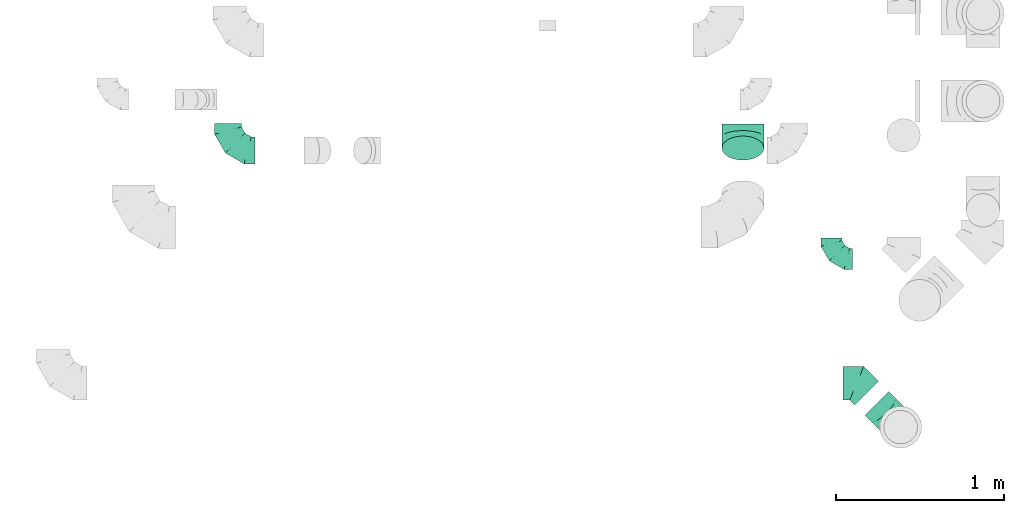
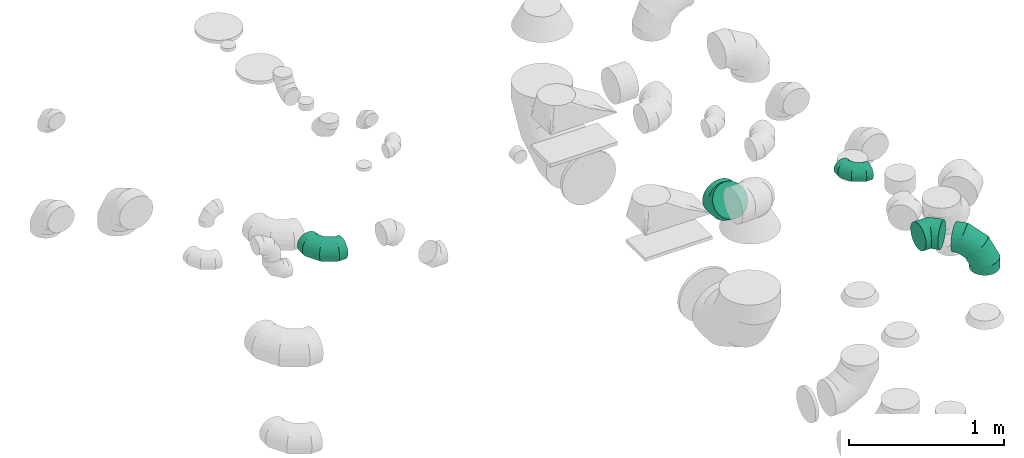
# One storey, part 41 of 59: 5 flow fittings.
"""IFC2X3 building model written with IfcOpenShell, lengths in millimetres."""

from ifc_helpers import new_model, entity, si_unit, converted_unit, derived_unit, direction, frame, origin, place, context, subcontext, project, spatial, faceted_brep, source, transform, mapped, material, type_object, type_shapes, element, save


model = new_model("IFC2X3")

# Units and contexts
model_context = context("Model", 3, precision=0.01, world=origin(), true_north=direction((6.12303176911189e-17, 1.0)))
body_context = subcontext(model_context, "Body", "Model", "MODEL_VIEW")
ifc_project = project(units=[si_unit("LENGTHUNIT", "METRE", prefix="MILLI"), si_unit("AREAUNIT", "SQUARE_METRE"), si_unit("VOLUMEUNIT", "CUBIC_METRE"), converted_unit("PLANEANGLEUNIT", "DEGREE", entity("IfcRatioMeasure", 0.0174532925199433), si_unit("PLANEANGLEUNIT", "RADIAN"), dimensions=[0, 0, 0, 0, 0, 0, 0]), si_unit("MASSUNIT", "GRAM", prefix="KILO"), derived_unit("MASSDENSITYUNIT", [(si_unit("MASSUNIT", "GRAM", prefix="KILO"), 1), (si_unit("LENGTHUNIT", "METRE"), -3)]), derived_unit("MOMENTOFINERTIAUNIT", [(si_unit("LENGTHUNIT", "METRE"), 4)]), si_unit("TIMEUNIT", "SECOND"), si_unit("FREQUENCYUNIT", "HERTZ"), si_unit("THERMODYNAMICTEMPERATUREUNIT", "DEGREE_CELSIUS"), derived_unit("THERMALTRANSMITTANCEUNIT", [(si_unit("MASSUNIT", "GRAM", prefix="KILO"), 1), (si_unit("THERMODYNAMICTEMPERATUREUNIT", "KELVIN"), -1), (si_unit("TIMEUNIT", "SECOND"), -3)]), derived_unit("VOLUMETRICFLOWRATEUNIT", [(si_unit("LENGTHUNIT", "METRE"), 3), (si_unit("TIMEUNIT", "SECOND"), -1)]), derived_unit("MASSFLOWRATEUNIT", [(si_unit("MASSUNIT", "GRAM", prefix="KILO"), 1), (si_unit("TIMEUNIT", "SECOND"), -1)]), derived_unit("ROTATIONALFREQUENCYUNIT", [(si_unit("TIMEUNIT", "SECOND"), -1)]), si_unit("ELECTRICCURRENTUNIT", "AMPERE"), si_unit("ELECTRICVOLTAGEUNIT", "VOLT"), si_unit("POWERUNIT", "WATT"), si_unit("FORCEUNIT", "NEWTON", prefix="KILO"), si_unit("ILLUMINANCEUNIT", "LUX"), si_unit("LUMINOUSFLUXUNIT", "LUMEN"), si_unit("LUMINOUSINTENSITYUNIT", "CANDELA"), derived_unit("USERDEFINED", [(si_unit("MASSUNIT", "GRAM", prefix="KILO"), -1), (si_unit("LENGTHUNIT", "METRE"), -2), (si_unit("TIMEUNIT", "SECOND"), 3), (si_unit("LUMINOUSFLUXUNIT", "LUMEN"), 1)]), derived_unit("LINEARVELOCITYUNIT", [(si_unit("LENGTHUNIT", "METRE"), 1), (si_unit("TIMEUNIT", "SECOND"), -1)]), si_unit("PRESSUREUNIT", "PASCAL"), derived_unit("USERDEFINED", [(si_unit("LENGTHUNIT", "METRE"), -2), (si_unit("MASSUNIT", "GRAM", prefix="KILO"), 1), (si_unit("TIMEUNIT", "SECOND"), -2)]), derived_unit("LINEARFORCEUNIT", [(si_unit("MASSUNIT", "GRAM", prefix="KILO"), 1), (si_unit("LENGTHUNIT", "METRE"), 1), (si_unit("TIMEUNIT", "SECOND"), -2), (si_unit("LENGTHUNIT", "METRE"), -1)]), derived_unit("PLANARFORCEUNIT", [(si_unit("MASSUNIT", "GRAM", prefix="KILO"), 1), (si_unit("LENGTHUNIT", "METRE"), 1), (si_unit("TIMEUNIT", "SECOND"), -2), (si_unit("LENGTHUNIT", "METRE"), -2)])], contexts=[model_context])

# Site, building, storey
site_placement = place(None, origin())
site = spatial("IfcSite", under=ifc_project, at=site_placement, CompositionType="ELEMENT")
building_placement = place(site_placement, origin())
building = spatial("IfcBuilding", under=site, at=building_placement, CompositionType="ELEMENT")
storey_placement = place(building_placement, frame((0.0, 0.0, 28200.0)))
storey = spatial("IfcBuildingStorey", under=building, at=storey_placement, CompositionType="ELEMENT", Elevation=28200.0)

# Flow fittings
ifc_material = material()
duct_fitting_type_1 = type_object("IfcDuctFittingType", PredefinedType="NOTDEFINED", material=ifc_material)
shared_shape_1 = source(origin(), body_context, "Body", "Brep", [
    faceted_brep([(-160.0, 0.0, -80.0), (-160.0, -20.71, -77.27), (-160.0, -40.0, -69.28), (-160.0, -56.57, -56.57), (-160.0, -69.28, -40.0), (-160.0, -77.27, -20.71), (-160.0, -80.0, 0.0), (-160.0, -77.27, 20.71), (-160.0, -69.28, 40.0), (-160.0, -56.57, 56.57), (-160.0, -40.0, 69.28), (-160.0, -20.71, 77.27), (-160.0, 0.0, 80.0), (-160.0, 20.71, 77.27), (-160.0, 40.0, 69.28), (-160.0, 56.57, 56.57), (-160.0, 69.28, 40.0), (-160.0, 77.27, 20.71), (-160.0, 80.0, 0.0), (-160.0, 77.27, -20.71), (-160.0, 69.28, -40.0), (-160.0, 56.57, -56.57), (-160.0, 40.0, -69.28), (-160.0, 20.71, -77.27), (-122.68, 20.71, 77.27), (-127.85, 40.0, 69.28), (-117.13, 0.0, 80.0), (-132.29, 56.57, 56.57), (-137.83, 77.27, 20.71), (-138.56, 80.0, 0.0), (-135.69, 69.28, 40.0), (-135.69, 69.28, -40.0), (-132.29, 56.57, -56.57), (-137.83, 77.27, -20.71), (-122.68, 20.71, -77.27), (-117.13, 0.0, -80.0), (-127.85, 40.0, -69.28), (-111.58, -20.71, -77.27), (-106.41, -40.0, -69.28), (-101.97, -56.57, -56.57), (-98.56, -69.28, -40.0), (-96.42, -77.27, -20.71), (-95.69, -80.0, 0.0), (-96.42, -77.27, 20.71), (-98.56, -69.28, 40.0), (-101.97, -56.57, 56.57), (-106.41, -40.0, 69.28), (-111.58, -20.71, 77.27), (-58.03, 58.03, 77.27), (-72.15, 72.15, 69.28), (-42.87, 42.87, 80.0), (-84.28, 84.28, 56.57), (-93.59, 93.59, 40.0), (-99.44, 99.44, 20.71), (-101.44, 101.44, 0.0), (-99.44, 99.44, -20.71), (-93.59, 93.59, -40.0), (-84.28, 84.28, -56.57), (-58.03, 58.03, -77.27), (-42.87, 42.87, -80.0), (-72.15, 72.15, -69.28), (-27.71, 27.71, -77.27), (-13.59, 13.59, -69.28), (-1.46, 1.46, -56.57), (7.85, -7.85, -40.0), (13.7, -13.7, -20.71), (15.69, -15.69, 0.0), (13.7, -13.7, 20.71), (7.85, -7.85, 40.0), (-1.46, 1.46, 56.57), (-13.59, 13.59, 69.28), (-27.71, 27.71, 77.27), (-20.71, 122.68, 77.27), (-40.0, 127.85, 69.28), (0.0, 117.13, 80.0), (-56.57, 132.29, 56.57), (-69.28, 135.69, 40.0), (-77.27, 137.83, 20.71), (-80.0, 138.56, 0.0), (-77.27, 137.83, -20.71), (-69.28, 135.69, -40.0), (-56.57, 132.29, -56.57), (-20.71, 122.68, -77.27), (0.0, 117.13, -80.0), (-40.0, 127.85, -69.28), (20.71, 111.58, -77.27), (40.0, 106.41, -69.28), (56.57, 101.97, -56.57), (69.28, 98.56, -40.0), (77.27, 96.42, -20.71), (80.0, 95.69, 0.0), (77.27, 96.42, 20.71), (69.28, 98.56, 40.0), (56.57, 101.97, 56.57), (40.0, 106.41, 69.28), (20.71, 111.58, 77.27), (-20.71, 160.0, -77.27), (-40.0, 160.0, -69.28), (-56.57, 160.0, -56.57), (-69.28, 160.0, -40.0), (-77.27, 160.0, -20.71), (-80.0, 160.0, 0.0), (-77.27, 160.0, 20.71), (-69.28, 160.0, 40.0), (-56.57, 160.0, 56.57), (-40.0, 160.0, 69.28), (-20.71, 160.0, 77.27), (0.0, 160.0, 80.0), (20.71, 160.0, 77.27), (40.0, 160.0, 69.28), (56.57, 160.0, 56.57), (69.28, 160.0, 40.0), (77.27, 160.0, 20.71), (80.0, 160.0, 0.0), (77.27, 160.0, -20.71), (69.28, 160.0, -40.0), (56.57, 160.0, -56.57), (40.0, 160.0, -69.28), (20.71, 160.0, -77.27), (0.0, 160.0, -80.0)], [[[0, 1, 2, 3, 4, 5, 6, 7, 8, 9, 10, 11, 12, 13, 14, 15, 16, 17, 18, 19, 20, 21, 22, 23]], [[24, 25, 14, 13]], [[26, 24, 13, 12]], [[14, 25, 27, 15]], [[28, 29, 18, 17]], [[30, 28, 17, 16]], [[15, 27, 30, 16]], [[20, 31, 32, 21]], [[33, 31, 20, 19]], [[18, 29, 33, 19]], [[34, 35, 0, 23]], [[36, 34, 23, 22]], [[32, 36, 22, 21]], [[1, 0, 35, 37]], [[2, 1, 37, 38]], [[3, 2, 38, 39]], [[5, 4, 40, 41]], [[6, 5, 41, 42]], [[39, 40, 4, 3]], [[6, 42, 43, 7]], [[7, 43, 44, 8]], [[8, 44, 45, 9]], [[9, 45, 46, 10]], [[10, 46, 47, 11]], [[26, 12, 11, 47]], [[48, 49, 25, 24]], [[50, 48, 24, 26]], [[27, 25, 49, 51]], [[52, 53, 28, 30]], [[51, 52, 30, 27]], [[29, 28, 53, 54]], [[55, 56, 31, 33]], [[54, 55, 33, 29]], [[32, 31, 56, 57]], [[58, 59, 35, 34]], [[60, 58, 34, 36]], [[57, 60, 36, 32]], [[37, 35, 59, 61]], [[38, 37, 61, 62]], [[39, 38, 62, 63]], [[41, 40, 64, 65]], [[42, 41, 65, 66]], [[63, 64, 40, 39]], [[43, 42, 66, 67]], [[44, 43, 67, 68]], [[68, 69, 45, 44]], [[46, 45, 69, 70]], [[47, 46, 70, 71]], [[26, 47, 71, 50]], [[72, 73, 49, 48]], [[74, 72, 48, 50]], [[51, 49, 73, 75]], [[76, 77, 53, 52]], [[75, 76, 52, 51]], [[54, 53, 77, 78]], [[79, 80, 56, 55]], [[78, 79, 55, 54]], [[57, 56, 80, 81]], [[82, 83, 59, 58]], [[84, 82, 58, 60]], [[81, 84, 60, 57]], [[61, 59, 83, 85]], [[62, 61, 85, 86]], [[63, 62, 86, 87]], [[65, 64, 88, 89]], [[66, 65, 89, 90]], [[87, 88, 64, 63]], [[67, 66, 90, 91]], [[68, 67, 91, 92]], [[92, 93, 69, 68]], [[70, 69, 93, 94]], [[71, 70, 94, 95]], [[50, 71, 95, 74]], [[96, 97, 98, 99, 100, 101, 102, 103, 104, 105, 106, 107, 108, 109, 110, 111, 112, 113, 114, 115, 116, 117, 118, 119]], [[72, 74, 107, 106]], [[73, 72, 106, 105]], [[75, 73, 105, 104]], [[77, 76, 103, 102]], [[78, 77, 102, 101]], [[75, 104, 103, 76]], [[78, 101, 100, 79]], [[79, 100, 99, 80]], [[80, 99, 98, 81]], [[84, 97, 96, 82]], [[82, 96, 119, 83]], [[84, 81, 98, 97]], [[118, 117, 86, 85]], [[119, 118, 85, 83]], [[116, 87, 86, 117]], [[88, 115, 114, 89]], [[89, 114, 113, 90]], [[115, 88, 87, 116]], [[112, 111, 92, 91]], [[113, 112, 91, 90]], [[111, 110, 93, 92]], [[95, 94, 109, 108]], [[74, 95, 108, 107]], [[110, 109, 94, 93]]]),
])
type_shapes(duct_fitting_type_1, [shared_shape_1])
flow_fitting_1_placement = place(storey_placement, frame((68604.23, 9693.42, 3700.0), z_axis=(0.0, 0.0, 1.0), x_axis=(0.0, -1.0, 0.0)))
element("IfcFlowFitting", 1, at=flow_fitting_1_placement, inside=storey, type_object=duct_fitting_type_1, material=ifc_material, context=body_context, shape_type="MappedRepresentation", body=[
    mapped(shared_shape_1, transform((0.0, 0.0, 0.0), scale=1.0)),
])
duct_fitting_type_2 = type_object("IfcDuctFittingType", PredefinedType="NOTDEFINED", material=ifc_material)
shared_shape_2 = source(origin(), body_context, "Body", "Brep", [
    faceted_brep([(-200.0, 0.0, -100.0), (-200.0, -25.88, -96.59), (-200.0, -50.0, -86.6), (-200.0, -70.71, -70.71), (-200.0, -86.6, -50.0), (-200.0, -96.59, -25.88), (-200.0, -100.0, 0.0), (-200.0, -96.59, 25.88), (-200.0, -86.6, 50.0), (-200.0, -70.71, 70.71), (-200.0, -50.0, 86.6), (-200.0, -25.88, 96.59), (-200.0, 0.0, 100.0), (-200.0, 25.88, 96.59), (-200.0, 50.0, 86.6), (-200.0, 70.71, 70.71), (-200.0, 86.6, 50.0), (-200.0, 96.59, 25.88), (-200.0, 100.0, 0.0), (-200.0, 96.59, -25.88), (-200.0, 86.6, -50.0), (-200.0, 70.71, -70.71), (-200.0, 50.0, -86.6), (-200.0, 25.88, -96.59), (-153.35, 25.88, 96.59), (-159.81, 50.0, 86.6), (-146.41, 0.0, 100.0), (-165.36, 70.71, 70.71), (-172.29, 96.59, 25.88), (-173.21, 100.0, 0.0), (-169.62, 86.6, 50.0), (-169.62, 86.6, -50.0), (-165.36, 70.71, -70.71), (-172.29, 96.59, -25.88), (-153.35, 25.88, -96.59), (-146.41, 0.0, -100.0), (-159.81, 50.0, -86.6), (-139.48, -25.88, -96.59), (-133.01, -50.0, -86.6), (-127.46, -70.71, -70.71), (-123.21, -86.6, -50.0), (-120.53, -96.59, -25.88), (-119.62, -100.0, 0.0), (-120.53, -96.59, 25.88), (-123.21, -86.6, 50.0), (-127.46, -70.71, 70.71), (-133.01, -50.0, 86.6), (-139.48, -25.88, 96.59), (-72.54, 72.54, 96.59), (-90.19, 90.19, 86.6), (-53.59, 53.59, 100.0), (-105.35, 105.35, 70.71), (-116.99, 116.99, 50.0), (-124.3, 124.3, 25.88), (-126.79, 126.79, 0.0), (-124.3, 124.3, -25.88), (-116.99, 116.99, -50.0), (-105.35, 105.35, -70.71), (-72.54, 72.54, -96.59), (-53.59, 53.59, -100.0), (-90.19, 90.19, -86.6), (-34.64, 34.64, -96.59), (-16.99, 16.99, -86.6), (-1.83, 1.83, -70.71), (9.81, -9.81, -50.0), (17.12, -17.12, -25.88), (19.62, -19.62, 0.0), (17.12, -17.12, 25.88), (9.81, -9.81, 50.0), (-1.83, 1.83, 70.71), (-16.99, 16.99, 86.6), (-34.64, 34.64, 96.59), (-25.88, 153.35, 96.59), (-50.0, 159.81, 86.6), (0.0, 146.41, 100.0), (-70.71, 165.36, 70.71), (-86.6, 169.62, 50.0), (-96.59, 172.29, 25.88), (-100.0, 173.21, 0.0), (-96.59, 172.29, -25.88), (-86.6, 169.62, -50.0), (-70.71, 165.36, -70.71), (-25.88, 153.35, -96.59), (0.0, 146.41, -100.0), (-50.0, 159.81, -86.6), (25.88, 139.48, -96.59), (50.0, 133.01, -86.6), (70.71, 127.46, -70.71), (86.6, 123.21, -50.0), (96.59, 120.53, -25.88), (100.0, 119.62, 0.0), (96.59, 120.53, 25.88), (86.6, 123.21, 50.0), (70.71, 127.46, 70.71), (50.0, 133.01, 86.6), (25.88, 139.48, 96.59), (-25.88, 200.0, -96.59), (-50.0, 200.0, -86.6), (-70.71, 200.0, -70.71), (-86.6, 200.0, -50.0), (-96.59, 200.0, -25.88), (-100.0, 200.0, 0.0), (-96.59, 200.0, 25.88), (-86.6, 200.0, 50.0), (-70.71, 200.0, 70.71), (-50.0, 200.0, 86.6), (-25.88, 200.0, 96.59), (0.0, 200.0, 100.0), (25.88, 200.0, 96.59), (50.0, 200.0, 86.6), (70.71, 200.0, 70.71), (86.6, 200.0, 50.0), (96.59, 200.0, 25.88), (100.0, 200.0, 0.0), (96.59, 200.0, -25.88), (86.6, 200.0, -50.0), (70.71, 200.0, -70.71), (50.0, 200.0, -86.6), (25.88, 200.0, -96.59), (0.0, 200.0, -100.0)], [[[0, 1, 2, 3, 4, 5, 6, 7, 8, 9, 10, 11, 12, 13, 14, 15, 16, 17, 18, 19, 20, 21, 22, 23]], [[24, 25, 14, 13]], [[26, 24, 13, 12]], [[14, 25, 27, 15]], [[28, 29, 18, 17]], [[30, 28, 17, 16]], [[15, 27, 30, 16]], [[20, 31, 32, 21]], [[33, 31, 20, 19]], [[18, 29, 33, 19]], [[34, 35, 0, 23]], [[36, 34, 23, 22]], [[32, 36, 22, 21]], [[1, 0, 35, 37]], [[2, 1, 37, 38]], [[38, 39, 3, 2]], [[5, 4, 40, 41]], [[6, 5, 41, 42]], [[39, 40, 4, 3]], [[6, 42, 43, 7]], [[7, 43, 44, 8]], [[8, 44, 45, 9]], [[9, 45, 46, 10]], [[10, 46, 47, 11]], [[26, 12, 11, 47]], [[48, 49, 25, 24]], [[50, 48, 24, 26]], [[27, 25, 49, 51]], [[52, 53, 28, 30]], [[51, 52, 30, 27]], [[29, 28, 53, 54]], [[55, 56, 31, 33]], [[54, 55, 33, 29]], [[32, 31, 56, 57]], [[58, 59, 35, 34]], [[60, 58, 34, 36]], [[57, 60, 36, 32]], [[37, 35, 59, 61]], [[38, 37, 61, 62]], [[39, 38, 62, 63]], [[41, 40, 64, 65]], [[42, 41, 65, 66]], [[63, 64, 40, 39]], [[43, 42, 66, 67]], [[44, 43, 67, 68]], [[68, 69, 45, 44]], [[46, 45, 69, 70]], [[47, 46, 70, 71]], [[26, 47, 71, 50]], [[72, 73, 49, 48]], [[74, 72, 48, 50]], [[51, 49, 73, 75]], [[76, 77, 53, 52]], [[75, 76, 52, 51]], [[54, 53, 77, 78]], [[79, 80, 56, 55]], [[78, 79, 55, 54]], [[57, 56, 80, 81]], [[82, 83, 59, 58]], [[84, 82, 58, 60]], [[81, 84, 60, 57]], [[61, 59, 83, 85]], [[62, 61, 85, 86]], [[63, 62, 86, 87]], [[65, 64, 88, 89]], [[66, 65, 89, 90]], [[87, 88, 64, 63]], [[67, 66, 90, 91]], [[68, 67, 91, 92]], [[92, 93, 69, 68]], [[70, 69, 93, 94]], [[71, 70, 94, 95]], [[50, 71, 95, 74]], [[96, 97, 98, 99, 100, 101, 102, 103, 104, 105, 106, 107, 108, 109, 110, 111, 112, 113, 114, 115, 116, 117, 118, 119]], [[72, 74, 107, 106]], [[73, 72, 106, 105]], [[75, 73, 105, 104]], [[102, 101, 78, 77]], [[103, 102, 77, 76]], [[75, 104, 103, 76]], [[78, 101, 100, 79]], [[79, 100, 99, 80]], [[80, 99, 98, 81]], [[84, 97, 96, 82]], [[82, 96, 119, 83]], [[84, 81, 98, 97]], [[118, 117, 86, 85]], [[119, 118, 85, 83]], [[116, 87, 86, 117]], [[88, 115, 114, 89]], [[89, 114, 113, 90]], [[115, 88, 87, 116]], [[91, 90, 113, 112]], [[92, 91, 112, 111]], [[111, 110, 93, 92]], [[95, 94, 109, 108]], [[74, 95, 108, 107]], [[110, 109, 94, 93]]]),
])
type_shapes(duct_fitting_type_2, [shared_shape_2])
flow_fitting_2_placement = place(storey_placement, frame((72605.18, 8046.98, 3400.0), z_axis=(0.707106781186564, 0.707106781186531, 0.0), x_axis=(0.707106781186531, -0.707106781186564, 0.0)))
element("IfcFlowFitting", 2, at=flow_fitting_2_placement, inside=storey, type_object=duct_fitting_type_2, material=ifc_material, context=body_context, shape_type="MappedRepresentation", body=[
    mapped(shared_shape_2, transform((0.0, 0.0, 0.0), scale=1.0)),
])
duct_fitting_type_3 = type_object("IfcDuctFittingType", PredefinedType="NOTDEFINED", material=ifc_material)
shared_shape_3 = source(origin(), body_context, "Body", "Brep", [
    faceted_brep([(-125.0, 0.0, -62.5), (-125.0, -16.18, -60.37), (-125.0, -31.25, -54.13), (-125.0, -44.19, -44.19), (-125.0, -54.13, -31.25), (-125.0, -60.37, -16.18), (-125.0, -62.5, 0.0), (-125.0, -60.37, 16.18), (-125.0, -54.13, 31.25), (-125.0, -44.19, 44.19), (-125.0, -31.25, 54.13), (-125.0, -16.18, 60.37), (-125.0, 0.0, 62.5), (-125.0, 16.18, 60.37), (-125.0, 31.25, 54.13), (-125.0, 44.19, 44.19), (-125.0, 54.13, 31.25), (-125.0, 60.37, 16.18), (-125.0, 62.5, 0.0), (-125.0, 60.37, -16.18), (-125.0, 54.13, -31.25), (-125.0, 44.19, -44.19), (-125.0, 31.25, -54.13), (-125.0, 16.18, -60.37), (-95.84, 16.18, 60.37), (-99.88, 31.25, 54.13), (-91.51, 0.0, 62.5), (-103.35, 44.19, 44.19), (-107.68, 60.37, 16.18), (-108.25, 62.5, 0.0), (-106.01, 54.13, 31.25), (-106.01, 54.13, -31.25), (-103.35, 44.19, -44.19), (-107.68, 60.37, -16.18), (-95.84, 16.18, -60.37), (-91.51, 0.0, -62.5), (-99.88, 31.25, -54.13), (-87.17, -16.18, -60.37), (-83.13, -31.25, -54.13), (-79.66, -44.19, -44.19), (-77.0, -54.13, -31.25), (-75.33, -60.37, -16.18), (-74.76, -62.5, 0.0), (-75.33, -60.37, 16.18), (-77.0, -54.13, 31.25), (-79.66, -44.19, 44.19), (-83.13, -31.25, 54.13), (-87.17, -16.18, 60.37), (-45.34, 45.34, 60.37), (-56.37, 56.37, 54.13), (-33.49, 33.49, 62.5), (-65.85, 65.85, 44.19), (-73.12, 73.12, 31.25), (-77.69, 77.69, 16.18), (-79.25, 79.25, 0.0), (-77.69, 77.69, -16.18), (-73.12, 73.12, -31.25), (-65.85, 65.85, -44.19), (-45.34, 45.34, -60.37), (-33.49, 33.49, -62.5), (-56.37, 56.37, -54.13), (-21.65, 21.65, -60.37), (-10.62, 10.62, -54.13), (-1.14, 1.14, -44.19), (6.13, -6.13, -31.25), (10.7, -10.7, -16.18), (12.26, -12.26, 0.0), (10.7, -10.7, 16.18), (6.13, -6.13, 31.25), (-1.14, 1.14, 44.19), (-10.62, 10.62, 54.13), (-21.65, 21.65, 60.37), (-16.18, 95.84, 60.37), (-31.25, 99.88, 54.13), (0.0, 91.51, 62.5), (-44.19, 103.35, 44.19), (-54.13, 106.01, 31.25), (-60.37, 107.68, 16.18), (-62.5, 108.25, 0.0), (-60.37, 107.68, -16.18), (-54.13, 106.01, -31.25), (-44.19, 103.35, -44.19), (-16.18, 95.84, -60.37), (0.0, 91.51, -62.5), (-31.25, 99.88, -54.13), (16.18, 87.17, -60.37), (31.25, 83.13, -54.13), (44.19, 79.66, -44.19), (54.13, 77.0, -31.25), (60.37, 75.33, -16.18), (62.5, 74.76, 0.0), (60.37, 75.33, 16.18), (54.13, 77.0, 31.25), (44.19, 79.66, 44.19), (31.25, 83.13, 54.13), (16.18, 87.17, 60.37), (-16.18, 125.0, -60.37), (-31.25, 125.0, -54.13), (-44.19, 125.0, -44.19), (-54.13, 125.0, -31.25), (-60.37, 125.0, -16.18), (-62.5, 125.0, 0.0), (-60.37, 125.0, 16.18), (-54.13, 125.0, 31.25), (-44.19, 125.0, 44.19), (-31.25, 125.0, 54.13), (-16.18, 125.0, 60.37), (0.0, 125.0, 62.5), (16.18, 125.0, 60.37), (31.25, 125.0, 54.13), (44.19, 125.0, 44.19), (54.13, 125.0, 31.25), (60.37, 125.0, 16.18), (62.5, 125.0, 0.0), (60.37, 125.0, -16.18), (54.13, 125.0, -31.25), (44.19, 125.0, -44.19), (31.25, 125.0, -54.13), (16.18, 125.0, -60.37), (0.0, 125.0, -62.5)], [[[0, 1, 2, 3, 4, 5, 6, 7, 8, 9, 10, 11, 12, 13, 14, 15, 16, 17, 18, 19, 20, 21, 22, 23]], [[24, 25, 14, 13]], [[26, 24, 13, 12]], [[14, 25, 27, 15]], [[28, 29, 18, 17]], [[30, 28, 17, 16]], [[15, 27, 30, 16]], [[20, 31, 32, 21]], [[33, 31, 20, 19]], [[18, 29, 33, 19]], [[34, 35, 0, 23]], [[36, 34, 23, 22]], [[21, 32, 36, 22]], [[1, 0, 35, 37]], [[2, 1, 37, 38]], [[38, 39, 3, 2]], [[5, 4, 40, 41]], [[6, 5, 41, 42]], [[39, 40, 4, 3]], [[6, 42, 43, 7]], [[7, 43, 44, 8]], [[45, 9, 8, 44]], [[9, 45, 46, 10]], [[10, 46, 47, 11]], [[26, 12, 11, 47]], [[48, 49, 25, 24]], [[50, 48, 24, 26]], [[27, 25, 49, 51]], [[52, 53, 28, 30]], [[51, 52, 30, 27]], [[29, 28, 53, 54]], [[55, 56, 31, 33]], [[54, 55, 33, 29]], [[57, 32, 31, 56]], [[58, 59, 35, 34]], [[60, 58, 34, 36]], [[57, 60, 36, 32]], [[37, 35, 59, 61]], [[38, 37, 61, 62]], [[39, 38, 62, 63]], [[41, 40, 64, 65]], [[42, 41, 65, 66]], [[63, 64, 40, 39]], [[43, 42, 66, 67]], [[44, 43, 67, 68]], [[68, 69, 45, 44]], [[46, 45, 69, 70]], [[47, 46, 70, 71]], [[26, 47, 71, 50]], [[72, 73, 49, 48]], [[74, 72, 48, 50]], [[51, 49, 73, 75]], [[76, 77, 53, 52]], [[75, 76, 52, 51]], [[54, 53, 77, 78]], [[79, 80, 56, 55]], [[78, 79, 55, 54]], [[81, 57, 56, 80]], [[82, 83, 59, 58]], [[84, 82, 58, 60]], [[81, 84, 60, 57]], [[61, 59, 83, 85]], [[62, 61, 85, 86]], [[63, 62, 86, 87]], [[65, 64, 88, 89]], [[66, 65, 89, 90]], [[87, 88, 64, 63]], [[67, 66, 90, 91]], [[68, 67, 91, 92]], [[92, 93, 69, 68]], [[70, 69, 93, 94]], [[71, 70, 94, 95]], [[50, 71, 95, 74]], [[96, 97, 98, 99, 100, 101, 102, 103, 104, 105, 106, 107, 108, 109, 110, 111, 112, 113, 114, 115, 116, 117, 118, 119]], [[72, 74, 107, 106]], [[73, 72, 106, 105]], [[75, 73, 105, 104]], [[77, 76, 103, 102]], [[78, 77, 102, 101]], [[75, 104, 103, 76]], [[78, 101, 100, 79]], [[79, 100, 99, 80]], [[80, 99, 98, 81]], [[96, 119, 83, 82]], [[97, 96, 82, 84]], [[84, 81, 98, 97]], [[83, 119, 118, 85]], [[85, 118, 117, 86]], [[116, 87, 86, 117]], [[88, 115, 114, 89]], [[89, 114, 113, 90]], [[115, 88, 87, 116]], [[91, 90, 113, 112]], [[92, 91, 112, 111]], [[111, 110, 93, 92]], [[95, 94, 109, 108]], [[74, 95, 108, 107]], [[110, 109, 94, 93]]]),
])
type_shapes(duct_fitting_type_3, [shared_shape_3])
flow_fitting_3_placement = place(storey_placement, frame((72193.8, 9047.75, 3450.0), z_axis=(0.0, 0.0, 1.0), x_axis=(0.0, -1.0, 0.0)))
element("IfcFlowFitting", 3, at=flow_fitting_3_placement, inside=storey, type_object=duct_fitting_type_3, material=ifc_material, context=body_context, shape_type="MappedRepresentation", body=[
    mapped(shared_shape_3, transform((0.0, 0.0, 0.0), scale=1.0)),
])
duct_fitting_type_4 = type_object("IfcDuctFittingType", PredefinedType="NOTDEFINED", material=ifc_material)
shared_shape_4 = source(origin(), body_context, "Body", "Brep", [
    faceted_brep([(-82.84, 0.0, -100.0), (-82.84, -25.88, -96.59), (-82.84, -50.0, -86.6), (-82.84, -70.71, -70.71), (-82.84, -86.6, -50.0), (-82.84, -96.59, -25.88), (-82.84, -100.0, 0.0), (-82.84, -96.59, 25.88), (-82.84, -86.6, 50.0), (-82.84, -70.71, 70.71), (-82.84, -50.0, 86.6), (-82.84, -25.88, 96.59), (-82.84, 0.0, 100.0), (-82.84, 25.88, 96.59), (-82.84, 50.0, 86.6), (-82.84, 70.71, 70.71), (-82.84, 86.6, 50.0), (-82.84, 96.59, 25.88), (-82.84, 100.0, 0.0), (-82.84, 96.59, -25.88), (-82.84, 86.6, -50.0), (-82.84, 70.71, -70.71), (-82.84, 50.0, -86.6), (-82.84, 25.88, -96.59), (-10.72, 25.88, 96.59), (-20.71, 50.0, 86.6), (0.0, 0.0, 100.0), (-29.29, 70.71, 70.71), (-35.87, 86.6, 50.0), (-40.01, 96.59, 25.88), (-41.42, 100.0, 0.0), (-40.01, 96.59, -25.88), (-35.87, 86.6, -50.0), (-29.29, 70.71, -70.71), (-10.72, 25.88, -96.59), (0.0, 0.0, -100.0), (-20.71, 50.0, -86.6), (10.72, -25.88, -96.59), (20.71, -50.0, -86.6), (29.29, -70.71, -70.71), (35.87, -86.6, -50.0), (40.01, -96.59, -25.88), (41.42, -100.0, 0.0), (40.01, -96.59, 25.88), (35.87, -86.6, 50.0), (29.29, -70.71, 70.71), (20.71, -50.0, 86.6), (10.72, -25.88, 96.59), (58.58, 58.58, 100.0), (40.28, 76.88, 96.59), (23.22, 93.93, 86.6), (8.58, 108.58, 70.71), (-2.66, 119.82, 50.0), (-9.72, 126.88, 25.88), (-12.13, 129.29, 0.0), (-9.72, 126.88, -25.88), (-2.66, 119.82, -50.0), (8.58, 108.58, -70.71), (23.22, 93.93, -86.6), (40.28, 76.88, -96.59), (58.58, 58.58, -100.0), (76.88, 40.28, -96.59), (93.93, 23.22, -86.6), (108.58, 8.58, -70.71), (119.82, -2.66, -50.0), (126.88, -9.72, -25.88), (129.29, -12.13, 0.0), (126.88, -9.72, 25.88), (119.82, -2.66, 50.0), (108.58, 8.58, 70.71), (93.93, 23.22, 86.6), (76.88, 40.28, 96.59)], [[[0, 1, 2, 3, 4, 5, 6, 7, 8, 9, 10, 11, 12, 13, 14, 15, 16, 17, 18, 19, 20, 21, 22, 23]], [[24, 25, 14, 13]], [[26, 24, 13, 12]], [[14, 25, 27, 15]], [[28, 29, 17, 16]], [[28, 16, 15, 27]], [[30, 18, 17, 29]], [[31, 32, 20, 19]], [[30, 31, 19, 18]], [[32, 33, 21, 20]], [[34, 35, 0, 23]], [[36, 34, 23, 22]], [[33, 36, 22, 21]], [[1, 0, 35, 37]], [[2, 1, 37, 38]], [[38, 39, 3, 2]], [[5, 4, 40, 41]], [[6, 5, 41, 42]], [[39, 40, 4, 3]], [[6, 42, 43, 7]], [[7, 43, 44, 8]], [[8, 44, 45, 9]], [[9, 45, 46, 10]], [[10, 46, 47, 11]], [[26, 12, 11, 47]], [[24, 26, 48, 49]], [[25, 24, 49, 50]], [[27, 25, 50, 51]], [[29, 28, 52, 53]], [[30, 29, 53, 54]], [[51, 52, 28, 27]], [[30, 54, 55, 31]], [[31, 55, 56, 32]], [[57, 33, 32, 56]], [[36, 58, 59, 34]], [[34, 59, 60, 35]], [[58, 36, 33, 57]], [[35, 60, 61, 37]], [[37, 61, 62, 38]], [[63, 39, 38, 62]], [[40, 64, 65, 41]], [[41, 65, 66, 42]], [[64, 40, 39, 63]], [[43, 42, 66, 67]], [[44, 43, 67, 68]], [[68, 69, 45, 44]], [[47, 46, 70, 71]], [[26, 47, 71, 48]], [[69, 70, 46, 45]], [[59, 58, 57, 56, 55, 54, 53, 52, 51, 50, 49, 48, 71, 70, 69, 68, 67, 66, 65, 64, 63, 62, 61, 60]]]),
])
type_shapes(duct_fitting_type_4, [shared_shape_4])
flow_fitting_4_placement = place(storey_placement, frame((72344.05, 8308.1, 3400.0), z_axis=(0.0, 0.0, 1.0), x_axis=(-0.707106781186544, 0.707106781186551, 0.0)))
element("IfcFlowFitting", 4, at=flow_fitting_4_placement, inside=storey, type_object=duct_fitting_type_4, material=ifc_material, context=body_context, shape_type="MappedRepresentation", body=[
    mapped(shared_shape_4, transform((0.0, 0.0, 0.0), scale=1.0)),
])
duct_fitting_type_5 = type_object("IfcDuctFittingType", PredefinedType="NOTDEFINED", material=ifc_material)
shared_shape_5 = source(origin(), body_context, "Body", "Brep", [
    faceted_brep([(-78.82, 0.0, -125.0), (-78.82, -32.35, -120.74), (-78.82, -62.5, -108.25), (-78.82, -88.39, -88.39), (-78.82, -108.25, -62.5), (-78.82, -120.74, -32.35), (-78.82, -125.0, 0.0), (-78.82, -120.74, 32.35), (-78.82, -108.25, 62.5), (-78.82, -88.39, 88.39), (-78.82, -62.5, 108.25), (-78.82, -32.35, 120.74), (-78.82, 0.0, 125.0), (-78.82, 32.35, 120.74), (-78.82, 62.5, 108.25), (-78.82, 88.39, 88.39), (-78.82, 108.25, 62.5), (-78.82, 120.74, 32.35), (-78.82, 125.0, 0.0), (-78.82, 120.74, -32.35), (-78.82, 108.25, -62.5), (-78.82, 88.39, -88.39), (-78.82, 62.5, -108.25), (-78.82, 32.35, -120.74), (-10.2, 32.35, 120.74), (-19.71, 62.5, 108.25), (0.0, 0.0, 125.0), (-27.87, 88.39, 88.39), (-34.13, 108.25, 62.5), (-38.07, 120.74, 32.35), (-39.41, 125.0, 0.0), (-38.07, 120.74, -32.35), (-34.13, 108.25, -62.5), (-27.87, 88.39, -88.39), (-10.2, 32.35, -120.74), (0.0, 0.0, -125.0), (-19.71, 62.5, -108.25), (10.2, -32.35, -120.74), (19.71, -62.5, -108.25), (27.87, -88.39, -88.39), (34.13, -108.25, -62.5), (38.07, -120.74, -32.35), (39.41, -125.0, 0.0), (38.07, -120.74, 32.35), (34.13, -108.25, 62.5), (27.87, -88.39, 88.39), (19.71, -62.5, 108.25), (10.2, -32.35, 120.74), (46.01, 71.71, 120.74), (28.72, 96.41, 108.25), (64.57, 45.21, 125.0), (13.87, 117.62, 88.39), (2.48, 133.89, 62.5), (-4.68, 144.12, 32.35), (-7.13, 147.61, 0.0), (-4.68, 144.12, -32.35), (2.48, 133.89, -62.5), (13.87, 117.62, -88.39), (28.72, 96.41, -108.25), (46.01, 71.71, -120.74), (64.57, 45.21, -125.0), (83.13, 18.71, -120.74), (100.42, -5.99, -108.25), (115.27, -27.19, -88.39), (126.66, -43.46, -62.5), (133.82, -53.69, -32.35), (136.27, -57.18, 0.0), (133.82, -53.69, 32.35), (126.66, -43.46, 62.5), (115.27, -27.19, 88.39), (100.42, -5.99, 108.25), (83.13, 18.71, 120.74)], [[[0, 1, 2, 3, 4, 5, 6, 7, 8, 9, 10, 11, 12, 13, 14, 15, 16, 17, 18, 19, 20, 21, 22, 23]], [[24, 25, 14, 13]], [[26, 24, 13, 12]], [[14, 25, 27, 15]], [[28, 29, 17, 16]], [[28, 16, 15, 27]], [[30, 18, 17, 29]], [[31, 32, 20, 19]], [[30, 31, 19, 18]], [[32, 33, 21, 20]], [[34, 35, 0, 23]], [[36, 34, 23, 22]], [[33, 36, 22, 21]], [[1, 0, 35, 37]], [[2, 1, 37, 38]], [[38, 39, 3, 2]], [[5, 4, 40, 41]], [[6, 5, 41, 42]], [[39, 40, 4, 3]], [[6, 42, 43, 7]], [[7, 43, 44, 8]], [[8, 44, 45, 9]], [[9, 45, 46, 10]], [[10, 46, 47, 11]], [[26, 12, 11, 47]], [[48, 49, 25, 24]], [[50, 48, 24, 26]], [[27, 25, 49, 51]], [[29, 28, 52, 53]], [[30, 29, 53, 54]], [[51, 52, 28, 27]], [[30, 54, 55, 31]], [[31, 55, 56, 32]], [[57, 33, 32, 56]], [[36, 58, 59, 34]], [[34, 59, 60, 35]], [[58, 36, 33, 57]], [[35, 60, 61, 37]], [[37, 61, 62, 38]], [[63, 39, 38, 62]], [[40, 64, 65, 41]], [[41, 65, 66, 42]], [[64, 40, 39, 63]], [[43, 42, 66, 67]], [[44, 43, 67, 68]], [[68, 69, 45, 44]], [[47, 46, 70, 71]], [[26, 47, 71, 50]], [[69, 70, 46, 45]], [[59, 58, 57, 56, 55, 54, 53, 52, 51, 49, 48, 50, 71, 70, 69, 68, 67, 66, 65, 64, 63, 62, 61, 60]]]),
])
type_shapes(duct_fitting_type_5, [shared_shape_5])
flow_fitting_5_placement = place(storey_placement, frame((71666.81, 9771.41, 3000.0), z_axis=(-1.0, 0.0, 0.0), x_axis=(0.0, -1.0, 0.0)))
element("IfcFlowFitting", 5, at=flow_fitting_5_placement, inside=storey, type_object=duct_fitting_type_5, material=ifc_material, context=body_context, shape_type="MappedRepresentation", body=[
    mapped(shared_shape_5, transform((0.0, 0.0, 0.0), scale=1.0)),
])

save(model, "model.ifc")
